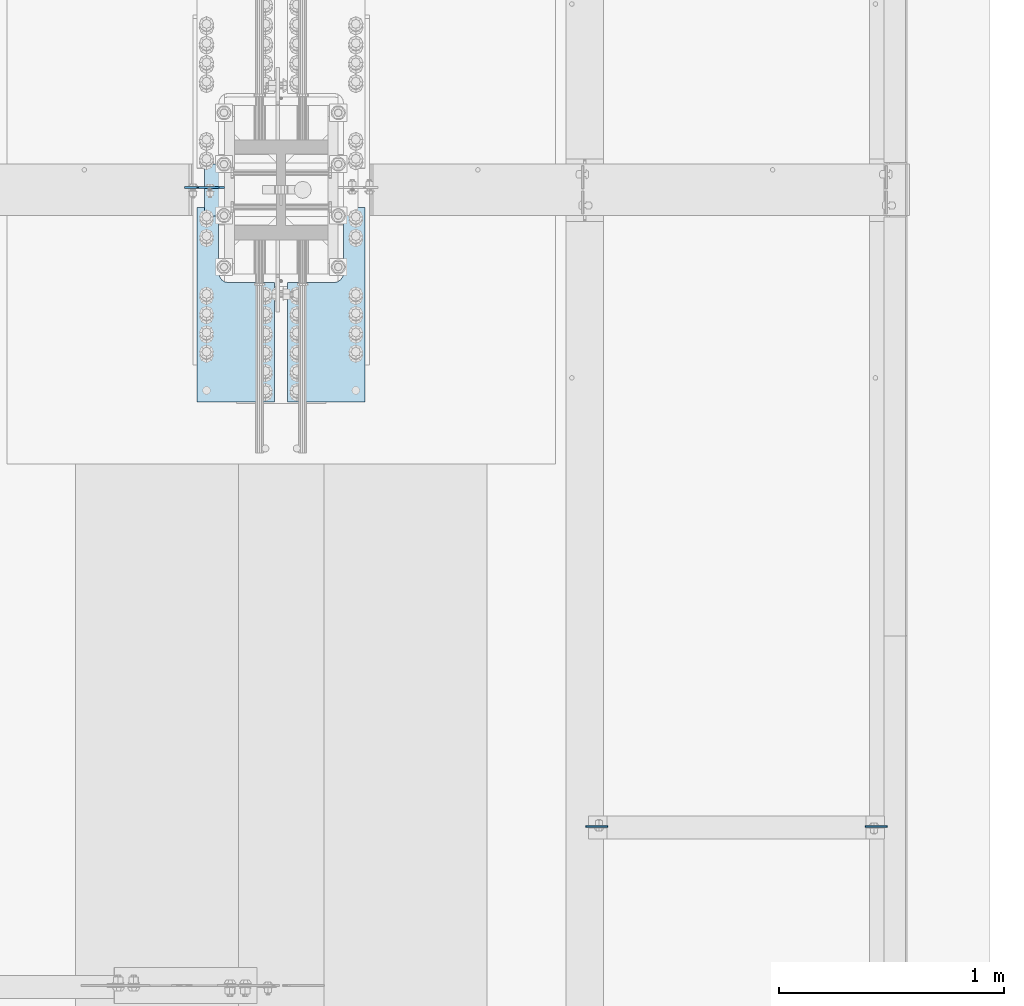
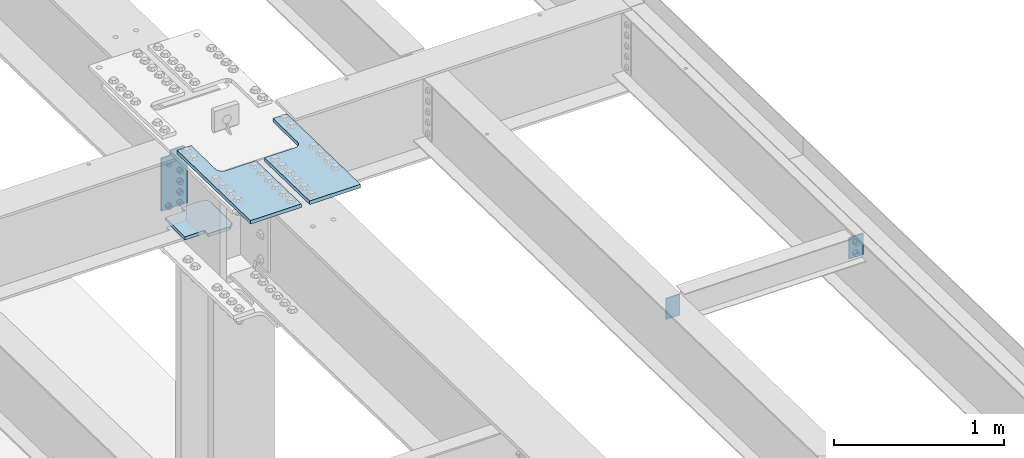
# One storey, part 1571 of 1763: 6 plates, 5 elements without a shape of their own.
"""IFC2X3 building model written with IfcOpenShell, lengths in millimetres."""

from ifc_helpers import new_model, si_unit, frame, origin_with_axes, place, context, subcontext, project, spatial, faceted_brep, material, type_object, element, aggregate, save


model = new_model("IFC2X3")

# Units and contexts
model_context = context("Model", 3, precision=1e-05, world=origin_with_axes())
body_context = subcontext(model_context, "Body", "Model", "MODEL_VIEW")
ifc_project = project(units=[si_unit("LENGTHUNIT", "METRE", prefix="MILLI"), si_unit("AREAUNIT", "SQUARE_METRE"), si_unit("VOLUMEUNIT", "CUBIC_METRE"), si_unit("MASSUNIT", "GRAM", prefix="KILO"), si_unit("TIMEUNIT", "SECOND"), si_unit("PLANEANGLEUNIT", "RADIAN"), si_unit("SOLIDANGLEUNIT", "STERADIAN"), si_unit("THERMODYNAMICTEMPERATUREUNIT", "DEGREE_CELSIUS"), si_unit("LUMINOUSINTENSITYUNIT", "LUMEN")], contexts=[model_context])

# Site, building, storey
site_placement = place(None, origin_with_axes())
site = spatial("IfcSite", under=ifc_project, at=site_placement, CompositionType="ELEMENT")
building_placement = place(site_placement, origin_with_axes())
building = spatial("IfcBuilding", under=site, at=building_placement, Name="Undefined", CompositionType="ELEMENT")
storey_placement = place(building_placement, origin_with_axes())
storey = spatial("IfcBuildingStorey", under=building, at=storey_placement, Name="Undefined", CompositionType="ELEMENT", Elevation=0.0)

# Assembly, plate
assembly_1_placement = place(storey_placement, origin_with_axes())
assembly_1 = element("IfcElementAssembly", 1, at=assembly_1_placement, inside=storey, Name="BEAM", AssemblyPlace="NOTDEFINED", PredefinedType="RIGID_FRAME")
ifc_material_1 = material(Name="STEEL/A36")
plate_type_1 = type_object("IfcPlateType", PredefinedType="NOTDEFINED")
plate_1_placement = place(assembly_1_placement, frame((-21333.8497736984, -2371.88374998189, 11935.9069384233), z_axis=(-1.0, 0.0, 0.0), x_axis=(0.0, 0.0, -1.0)))
plate_1 = element("IfcPlate", 2, at=plate_1_placement, type_object=plate_type_1, material=ifc_material_1, Name="PLATE", context=body_context, shape_type="Brep", body=[
    faceted_brep([(1.81898940354586e-12, -3.17500000000291, 0.0), (0.0, -3.17499999999927, 96.8375015258789), (0.0, 3.17499999999927, 96.8375015258789), (-1.81898940354586e-12, 3.17499999997381, 0.0), (152.399993896484, -3.17499999999927, 96.8375015258789), (152.399993896484, 3.17499999999927, 96.8375015258789), (152.399993896484, -3.17500000000291, 0.0), (152.399993896484, 3.17500000000291, 0.0)], [[[0, 1, 2, 3]], [[1, 4, 5, 2]], [[4, 6, 7, 5]], [[6, 0, 3, 7]], [[5, 7, 3, 2]], [[6, 4, 1, 0]]]),
])
aggregate(assembly_1, [plate_1])

assembly_2_placement = place(storey_placement, origin_with_axes())
assembly_2 = element("IfcElementAssembly", 3, at=assembly_2_placement, inside=storey, Name="BEAM", AssemblyPlace="NOTDEFINED", PredefinedType="RIGID_FRAME")
plate_2_placement = place(assembly_2_placement, frame((-22673.6997736984, -2371.88374998189, 11935.9069384233), z_axis=(1.0, 0.0, 0.0), x_axis=(0.0, 0.0, -1.0)))
plate_2 = element("IfcPlate", 4, at=plate_2_placement, type_object=plate_type_1, material=ifc_material_1, Name="PLATE", context=body_context, shape_type="Brep", body=[
    faceted_brep([(1.81898940354586e-12, -3.17500000000291, 0.0), (0.0, -3.17499999999927, 96.8375015258789), (0.0, 3.17499999999927, 96.8375015258789), (-1.81898940354586e-12, 3.17499999997381, 0.0), (152.399993896484, -3.17499999999927, 96.8375015258789), (152.399993896484, 3.17499999999927, 96.8375015258789), (152.399993896484, -3.17500000000291, 0.0), (152.399993896484, 3.17500000000291, 0.0)], [[[0, 1, 2, 3]], [[1, 4, 5, 2]], [[4, 6, 7, 5]], [[6, 0, 3, 7]], [[5, 7, 3, 2]], [[6, 4, 1, 0]]]),
])
aggregate(assembly_2, [plate_2])

# Assembly, plates
assembly_3_placement = place(storey_placement, origin_with_axes())
assembly_3 = element("IfcElementAssembly", 5, at=assembly_3_placement, inside=storey, Name="COLUMN", AssemblyPlace="NOTDEFINED", PredefinedType="RIGID_FRAME")
ifc_material_2 = material(Name="STEEL/A572-50")
plate_type_2 = type_object("IfcPlateType", PredefinedType="NOTDEFINED")
plate_3_placement = place(assembly_3_placement, frame((-24369.1497736984, 300.037499999998, 11313.0836714953), z_axis=(0.0, 1.0, 0.0), x_axis=(1.0, 0.0, 0.0)))
plate_3 = element("IfcPlate", 6, at=plate_3_placement, type_object=plate_type_2, material=ifc_material_2, Name="PLATE", context=body_context, shape_type="Brep", body=[
    faceted_brep([(321.46875, -1.1446269127191e-05, 276.22501373291), (310.356261446268, -11.1124999999993, 287.337502286641), (310.356261446268, -11.1124999999993, 26.9875099203902), (321.46875, -1.1446269127191e-05, 38.0999984741211), (283.368751525879, -11.1124999999993, 314.325012207031), (283.368751525879, 11.1124999999993, 314.325012207031), (134.937499917411, 11.1124999999993, 314.325012207031), (134.937499917411, -11.1124999999993, 314.325009425155), (134.937499999996, 11.1124999999993, 273.050000269877), (134.937499999996, -11.1124999999993, 273.050000269877), (0.0, 11.1124999999993, 273.050000000009), (0.0, -11.1124999999993, 273.050000000009), (0.0, 11.1124999999993, 41.2750088856509), (0.0, -11.1124999999993, 41.2750088856509), (283.368751525879, 11.1124999999993, 0.0), (283.368751525879, -11.1124999999993, 0.0), (134.937499999996, -11.1124999999993, 0.0), (134.937499999996, 11.1124999999993, 0.0), (134.937499917411, -11.1124999999993, 41.275009155523), (134.937499917411, 11.1124999999993, 41.275009155523), (321.46875, 11.1124999999993, 276.22501373291), (321.46875, 11.1124999999993, 38.0999984741211)], [[[0, 1, 2, 3]], [[4, 5, 6, 7]], [[7, 6, 8, 9]], [[9, 8, 10, 11]], [[11, 10, 12, 13]], [[14, 15, 16, 17]], [[18, 19, 17, 16]], [[13, 12, 19, 18]], [[10, 8, 6, 5, 20, 21, 14, 17, 19, 12]], [[21, 20, 0, 3]], [[15, 14, 21, 3, 2]], [[4, 7, 9, 11, 13, 18, 16, 15, 2, 1]], [[20, 5, 4, 1, 0]]]),
])
ifc_material_3 = material(Name="STEEL/A572-GR.50")
plate_type_3 = type_object("IfcPlateType", PredefinedType="NOTDEFINED")
plate_4_placement = place(assembly_3_placement, frame((-24280.2497736984, 467.518750000001, 11881.4086714953), z_axis=(-1.0, 0.0, 0.0), x_axis=(0.0, 0.0, -1.0)))
plate_4 = element("IfcPlate", 7, at=plate_4_placement, type_object=plate_type_3, material=ifc_material_3, Name="PLATE", context=body_context, shape_type="Brep", body=[
    faceted_brep([(23.8124986648563, -4.76249999999999, 114.300003051765), (23.8124986648563, 4.76249999999999, 114.300003051765), (4.17836417909712e-07, 4.76249999999709, 114.300003051758), (4.17818228015676e-07, -4.76249999999709, 114.300003051758), (28.6725781829027, -4.76249999999999, 115.266732974353), (28.6725781829027, 4.76249999999999, 115.266732974353), (32.7927546510564, -4.76249999999999, 118.01974687483), (32.7927546510564, 4.76249999999999, 118.01974687483), (35.5457685515339, -4.76249999999999, 122.139923342984), (35.5457685515339, 4.76249999999999, 122.139923342984), (36.5124984741215, -4.76249999999999, 127.00000286103), (36.5124984741215, 4.76249999999999, 127.00000286103), (36.5124984741215, -4.76249999999999, 177.800003051765), (36.5124984741215, 4.76249999999999, 177.800003051758), (23.8124996185306, -4.76249999999999, 7.27595761418343e-12), (0.0, -4.76249999999999, 23.8124996185361), (0.0, 4.76249999999999, 23.8124996185361), (23.8124996185306, 4.76249999999999, 0.0), (417.512512207031, 4.76249999999999, 0.0), (417.512512207031, -4.76249999999999, 0.0), (417.512512207031, -4.76249999999999, 177.800003051758), (417.512512207031, 4.76249999999999, 177.800003051758)], [[[0, 1, 2, 3]], [[4, 5, 1, 0]], [[6, 7, 5, 4]], [[8, 9, 7, 6]], [[10, 11, 9, 8]], [[12, 13, 11, 10]], [[14, 15, 16, 17]], [[18, 19, 14, 17]], [[20, 19, 18, 21]], [[8, 6, 4, 0, 3, 15, 14, 19, 20, 12, 10]], [[16, 15, 3, 2]], [[21, 18, 17, 16, 2, 1, 5, 7, 9, 11, 13]], [[20, 21, 13, 12]]]),
])
aggregate(assembly_3, [plate_3, plate_4])

# Assembly, plate
assembly_4_placement = place(storey_placement, origin_with_axes())
assembly_4 = element("IfcElementAssembly", 8, at=assembly_4_placement, inside=storey, Name="PLATE", AssemblyPlace="NOTDEFINED", PredefinedType="RIGID_FRAME")
plate_type_4 = type_object("IfcPlateType", PredefinedType="NOTDEFINED")
plate_5_placement = place(assembly_4_placement, frame((-24400.8345768876, -485.377125438805, 11940.8044694681), z_axis=(0.0, 0.999781542776098, -0.0209013569953182), x_axis=(1.0, 0.0, 0.0)))
plate_5 = element("IfcPlate", 9, at=plate_5_placement, type_object=plate_type_4, material=ifc_material_2, Name="PLATE", context=body_context, shape_type="Brep", body=[
    faceted_brep([(95.2499843867117, -12.7000000006265, 863.630004882794), (95.2499843867117, -12.7000000004155, 574.700031279008), (95.2499843867117, 12.6999999995751, 574.700031431355), (95.2499843867117, 12.6999999993604, 863.630004882794), (98.6335392246619, -12.7000000004027, 557.689752418416), (98.6335392246619, 12.699999999586, 557.689752570763), (108.269088186429, -12.7000000003918, 543.269134315787), (108.269088186429, 12.6999999995951, 543.269134468135), (122.68970628906, -12.7000000003864, 533.633585354019), (122.68970628906, 12.6999999996024, 533.633585506366), (139.699985149651, -12.7000000003809, 530.25003051607), (139.699985149651, 12.699999999606, 530.250030668418), (344.487517956048, -12.7000000003809, 530.25003051607), (344.487518310547, 12.699999999606, 530.250030668417), (0.0, -12.6999999999971, -1.81898940354586e-12), (-3.63797880709171e-12, -12.7000000006265, 863.630004882794), (-3.63797880709171e-12, 12.6999999993604, 863.630004882794), (0.0, 12.6999999999971, -1.81898940354586e-12), (344.487518310547, -12.6999999999935, 2.27373675443232e-13), (344.487518310547, 12.6999999999935, -2.27373675443232e-13)], [[[0, 1, 2, 3]], [[4, 5, 2, 1]], [[6, 7, 5, 4]], [[8, 9, 7, 6]], [[10, 11, 9, 8]], [[12, 13, 11, 10]], [[14, 15, 16, 17]], [[18, 14, 17, 19]], [[8, 6, 4, 1, 0, 15, 14, 18, 12, 10]], [[16, 15, 0, 3]], [[19, 17, 16, 3, 2, 5, 7, 9, 11, 13]], [[18, 19, 13, 12]]]),
])
aggregate(assembly_4, [plate_5])

assembly_5_placement = place(storey_placement, origin_with_axes())
assembly_5 = element("IfcElementAssembly", 10, at=assembly_5_placement, inside=storey, Name="PLATE", AssemblyPlace="NOTDEFINED", PredefinedType="RIGID_FRAME")
plate_6_placement = place(assembly_5_placement, frame((-23654.7747981124, -485.377125438798, 11940.8044694681), z_axis=(0.0, 0.999781542776098, -0.0209013569953182), x_axis=(-1.0, 0.0, 0.0)))
plate_6 = element("IfcPlate", 11, at=plate_6_placement, type_object=plate_type_4, material=ifc_material_2, Name="PLATE", context=body_context, shape_type="Brep", body=[
    faceted_brep([(95.2499843867117, -12.7000000006265, 863.630004882794), (95.2499843867117, -12.7000000004155, 574.700031279008), (95.2499843867117, 12.6999999995751, 574.700031431355), (95.2499843867117, 12.6999999993604, 863.630004882794), (98.6335392246619, -12.7000000004027, 557.689752418416), (98.6335392246619, 12.699999999586, 557.689752570763), (108.269088186429, -12.7000000003918, 543.269134315787), (108.269088186429, 12.6999999995951, 543.269134468135), (122.68970628906, -12.7000000003864, 533.633585354019), (122.68970628906, 12.6999999996024, 533.633585506366), (139.699985149651, -12.7000000003809, 530.25003051607), (139.699985149651, 12.699999999606, 530.250030668418), (344.487517956048, -12.7000000003809, 530.25003051607), (344.487518310547, 12.699999999606, 530.250030668417), (0.0, -12.6999999999971, -1.81898940354586e-12), (-3.63797880709171e-12, -12.7000000006265, 863.630004882794), (-3.63797880709171e-12, 12.6999999993604, 863.630004882794), (0.0, 12.6999999999971, -1.81898940354586e-12), (344.487518310547, -12.6999999999935, 2.27373675443232e-13), (344.487518310547, 12.6999999999935, -2.27373675443232e-13)], [[[0, 1, 2, 3]], [[4, 5, 2, 1]], [[6, 7, 5, 4]], [[8, 9, 7, 6]], [[10, 11, 9, 8]], [[12, 13, 11, 10]], [[14, 15, 16, 17]], [[18, 14, 17, 19]], [[8, 6, 4, 1, 0, 15, 14, 18, 12, 10]], [[16, 15, 0, 3]], [[19, 17, 16, 3, 2, 5, 7, 9, 11, 13]], [[18, 19, 13, 12]]]),
])
aggregate(assembly_5, [plate_6])

save(model, "model.ifc")
